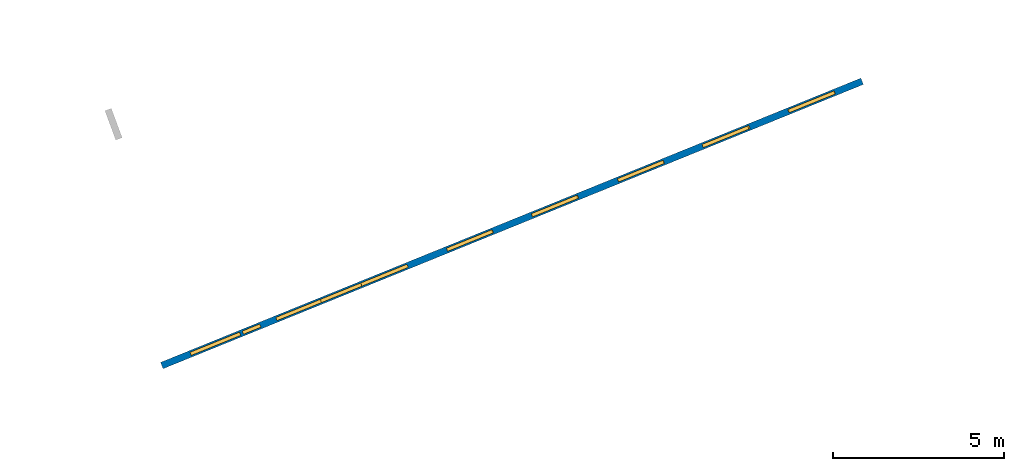
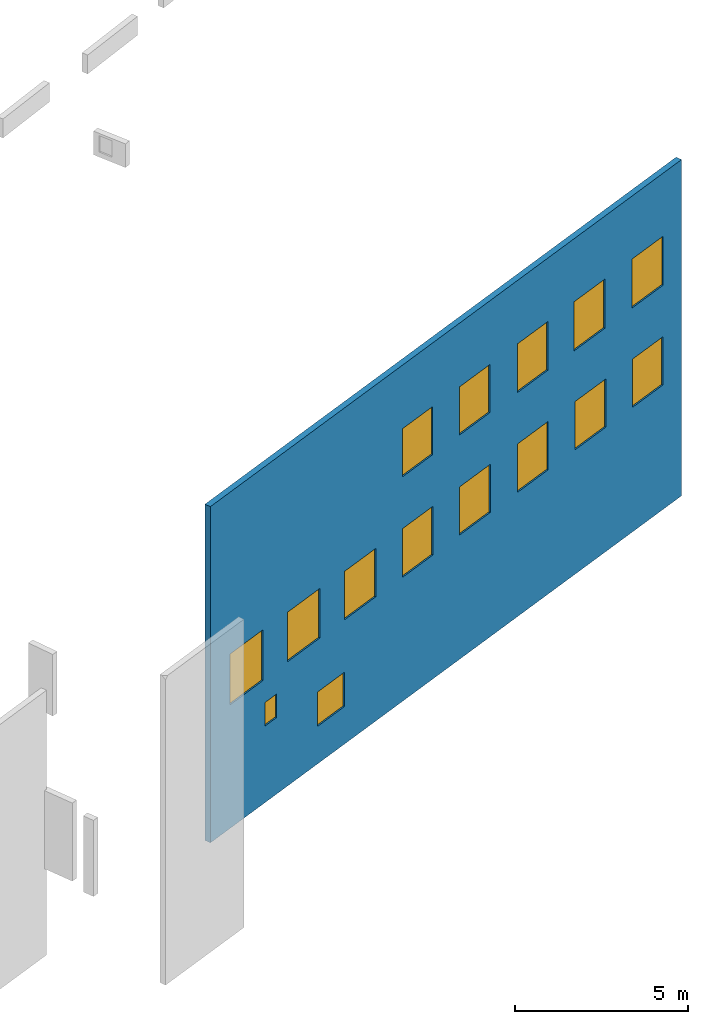
# One storey, part 4 of 27: 15 windows, 1 wall, 15 openings.
"""IFC2X3 building model written with IfcOpenShell, lengths in metres."""

from ifc_helpers import new_model, entity, si_unit, converted_unit, derived_unit, direction, frame, frame_2d, origin, origin_2d_with_axis, place, context, subcontext, project, spatial, polyline, rectangle, outline, extrude, source, transform, mapped, material, layer, layer_set, layer_usage, type_object, type_shapes, element, fill, save


model = new_model("IFC2X3")

# Units and contexts
model_context = context("Model", 3, precision=1e-05, world=origin(), true_north=direction((0.0, 1.0)))
body_context = subcontext(model_context, "Body", "Model", "MODEL_VIEW")
ifc_project = project(units=[si_unit("LENGTHUNIT", "METRE"), si_unit("AREAUNIT", "SQUARE_METRE"), si_unit("VOLUMEUNIT", "CUBIC_METRE"), converted_unit("PLANEANGLEUNIT", "DEGREE", entity("IfcRatioMeasure", 0.0174532925199433), si_unit("PLANEANGLEUNIT", "RADIAN"), dimensions=[0, 0, 0, 0, 0, 0, 0]), si_unit("MASSUNIT", "GRAM", prefix="KILO"), derived_unit("MASSDENSITYUNIT", [(si_unit("MASSUNIT", "GRAM", prefix="KILO"), 1), (si_unit("LENGTHUNIT", "METRE"), -3)]), derived_unit("MOMENTOFINERTIAUNIT", [(si_unit("LENGTHUNIT", "METRE"), 4)]), si_unit("TIMEUNIT", "SECOND"), si_unit("FREQUENCYUNIT", "HERTZ"), si_unit("THERMODYNAMICTEMPERATUREUNIT", "DEGREE_CELSIUS"), derived_unit("THERMALTRANSMITTANCEUNIT", [(si_unit("MASSUNIT", "GRAM", prefix="KILO"), 1), (si_unit("THERMODYNAMICTEMPERATUREUNIT", "KELVIN"), -1), (si_unit("TIMEUNIT", "SECOND"), -3)]), derived_unit("VOLUMETRICFLOWRATEUNIT", [(si_unit("LENGTHUNIT", "METRE"), 3), (si_unit("TIMEUNIT", "SECOND"), -1)]), si_unit("ELECTRICCURRENTUNIT", "AMPERE"), si_unit("ELECTRICVOLTAGEUNIT", "VOLT"), si_unit("POWERUNIT", "WATT"), si_unit("FORCEUNIT", "NEWTON", prefix="KILO"), si_unit("ILLUMINANCEUNIT", "LUX"), si_unit("LUMINOUSFLUXUNIT", "LUMEN"), si_unit("LUMINOUSINTENSITYUNIT", "CANDELA"), derived_unit("USERDEFINED", [(si_unit("MASSUNIT", "GRAM", prefix="KILO"), -1), (si_unit("LENGTHUNIT", "METRE"), -2), (si_unit("TIMEUNIT", "SECOND"), 3), (si_unit("LUMINOUSFLUXUNIT", "LUMEN"), 1)]), derived_unit("LINEARVELOCITYUNIT", [(si_unit("LENGTHUNIT", "METRE"), 1), (si_unit("TIMEUNIT", "SECOND"), -1)]), si_unit("PRESSUREUNIT", "PASCAL"), derived_unit("USERDEFINED", [(si_unit("LENGTHUNIT", "METRE"), -2), (si_unit("MASSUNIT", "GRAM", prefix="KILO"), 1), (si_unit("TIMEUNIT", "SECOND"), -2)]), derived_unit("LINEARFORCEUNIT", [(si_unit("MASSUNIT", "GRAM", prefix="KILO"), 1), (si_unit("LENGTHUNIT", "METRE"), 1), (si_unit("TIMEUNIT", "SECOND"), -2), (si_unit("LENGTHUNIT", "METRE"), -1)]), derived_unit("PLANARFORCEUNIT", [(si_unit("MASSUNIT", "GRAM", prefix="KILO"), 1), (si_unit("LENGTHUNIT", "METRE"), 1), (si_unit("TIMEUNIT", "SECOND"), -2), (si_unit("LENGTHUNIT", "METRE"), -2)])], contexts=[model_context])

# Site, building, storey
placement_1 = place(None, origin())
site = spatial("IfcSite", under=ifc_project, at=placement_1, CompositionType="ELEMENT")
building = spatial("IfcBuilding", under=site, at=placement_1, CompositionType="ELEMENT")
storey_placement = place(placement_1, frame((0.0, 0.0, -61.043098449707)))
storey = spatial("IfcBuildingStorey", under=building, at=storey_placement, Name="level_-61.043098", CompositionType="ELEMENT", Elevation=-61.043098449707)

# Wall, openings, windows
ifc_material_1 = material(Name="Default wall")
ifc_layer = layer(ifc_material_1, 0.2)
ifc_layer_set = layer_set([ifc_layer], Name="wall_thickness_0.2000")
ifc_layer_usage = layer_usage(ifc_layer_set, "AXIS2", "POSITIVE", -0.1)
wall_type = type_object("IfcWallType", Name="wall_thickness_0.2000", PredefinedType="STANDARD", material=ifc_layer_set)
placement_2 = place(placement_1, frame((0.0, 0.0, -60.9578857421875)))
wall_placement = place(placement_2, frame((-3.76886446488196, -59.6963670250745, 0.0), z_axis=(0.0, 0.0, 1.0), x_axis=(0.9265685084533, 0.37612604156403, 0.0)))
wall = element("IfcWallStandardCase", 1, at=wall_placement, inside=storey, type_object=wall_type, material=ifc_layer_usage, Name="Wall:1304", ObjectType="Wall", context=body_context, shape_type="SweptSolid", body=[
    extrude(outline(polyline([(22.1250003143564, -0.1), (22.1250003143564, 0.1), (0.0, 0.1), (0.0, -0.1), (22.1250003143564, -0.1)])), origin(), (0.0, 0.0, 1.0), 11.8396759033203),
])
opening_1_placement = place(wall_placement, frame((5.02385632715691, -0.1, 1.32223892211914)))
opening_1 = element("IfcOpeningElement", 2, at=opening_1_placement, cuts=wall, Name="Opening : 1275 x 1210 : 173", ObjectType="Opening", context=body_context, shape_type="SweptSolid", body=[
    extrude(rectangle(XDim=1.275, YDim=1.21, at=frame_2d((0.605, 0.6375), x_axis=(0.0, 1.0))), frame((0.0, 0.0, 0.0), z_axis=(0.0, 1.0, 0.0), x_axis=(0.0, 0.0, 1.0)), (0.0, 0.0, 1.0), 0.2),
])
opening_2_placement = place(wall_placement, frame((17.0849989237, -0.1, 7.89074325561523)))
opening_2 = element("IfcOpeningElement", 3, at=opening_2_placement, cuts=wall, Name="Opening : 1440 x 1730 : 174", ObjectType="Opening", context=body_context, shape_type="SweptSolid", body=[
    extrude(rectangle(XDim=1.44, YDim=1.73, at=frame_2d((0.865, 0.72), x_axis=(0.0, 1.0))), frame((0.0, 0.0, 0.0), z_axis=(0.0, 1.0, 0.0), x_axis=(0.0, 0.0, 1.0)), (0.0, 0.0, 1.0), 0.2),
])
opening_3_placement = place(wall_placement, frame((19.7949986488983, -0.1, 7.89574432373047)))
opening_3 = element("IfcOpeningElement", 4, at=opening_3_placement, cuts=wall, Name="Opening : 1465 x 1725 : 175", ObjectType="Opening", context=body_context, shape_type="SweptSolid", body=[
    extrude(rectangle(XDim=1.465, YDim=1.725, at=frame_2d((0.8625, 0.7325), x_axis=(0.0, 1.0))), frame((0.0, 0.0, 0.0), z_axis=(0.0, 1.0, 0.0), x_axis=(0.0, 0.0, 1.0)), (0.0, 0.0, 1.0), 0.2),
])
opening_4_placement = place(wall_placement, frame((9.00999836878025, -0.1, 7.90574264526367)))
opening_4 = element("IfcOpeningElement", 5, at=opening_4_placement, cuts=wall, Name="Opening : 1430 x 1695 : 176", ObjectType="Opening", context=body_context, shape_type="SweptSolid", body=[
    extrude(rectangle(XDim=1.43, YDim=1.695, at=frame_2d((0.8475, 0.715), x_axis=(0.0, 1.0))), frame((0.0, 0.0, 0.0), z_axis=(0.0, 1.0, 0.0), x_axis=(0.0, 0.0, 1.0)), (0.0, 0.0, 1.0), 0.2),
])
opening_5_placement = place(wall_placement, frame((14.414998605736, -0.1, 7.89074325561523)))
opening_5 = element("IfcOpeningElement", 6, at=opening_5_placement, cuts=wall, Name="Opening : 1430 x 1715 : 177", ObjectType="Opening", context=body_context, shape_type="SweptSolid", body=[
    extrude(rectangle(XDim=1.43, YDim=1.715, at=frame_2d((0.8575, 0.715), x_axis=(0.0, 1.0))), frame((0.0, 0.0, 0.0), z_axis=(0.0, 1.0, 0.0), x_axis=(0.0, 0.0, 1.0)), (0.0, 0.0, 1.0), 0.2),
])
opening_6_placement = place(wall_placement, frame((11.6899988972545, -0.1, 7.90074157714844)))
opening_6 = element("IfcOpeningElement", 7, at=opening_6_placement, cuts=wall, Name="Opening : 1430 x 1695 : 178", ObjectType="Opening", context=body_context, shape_type="SweptSolid", body=[
    extrude(rectangle(XDim=1.43, YDim=1.695, at=frame_2d((0.8475, 0.715), x_axis=(0.0, 1.0))), frame((0.0, 0.0, 0.0), z_axis=(0.0, 1.0, 0.0), x_axis=(0.0, 0.0, 1.0)), (0.0, 0.0, 1.0), 0.2),
])
opening_7_placement = place(wall_placement, frame((0.909998722391672, -0.1, 4.35074234008789)))
opening_7 = element("IfcOpeningElement", 8, at=opening_7_placement, cuts=wall, Name="Opening : 1565 x 1790 : 179", ObjectType="Opening", context=body_context, shape_type="SweptSolid", body=[
    extrude(rectangle(XDim=1.565, YDim=1.79, at=frame_2d((0.895, 0.7825), x_axis=(0.0, 1.0))), frame((0.0, 0.0, 0.0), z_axis=(0.0, 1.0, 0.0), x_axis=(0.0, 0.0, 1.0)), (0.0, 0.0, 1.0), 0.2),
])
opening_8_placement = place(wall_placement, frame((3.62000032421919, -0.1, 4.3757438659668)))
opening_8 = element("IfcOpeningElement", 9, at=opening_8_placement, cuts=wall, Name="Opening : 1525 x 1745 : 180", ObjectType="Opening", context=body_context, shape_type="SweptSolid", body=[
    extrude(rectangle(XDim=1.525, YDim=1.745, at=frame_2d((0.8725, 0.7625), x_axis=(0.0, 1.0))), frame((0.0, 0.0, 0.0), z_axis=(0.0, 1.0, 0.0), x_axis=(0.0, 0.0, 1.0)), (0.0, 0.0, 1.0), 0.2),
])
opening_9_placement = place(wall_placement, frame((6.30499908131936, -0.1, 4.3757438659668)))
opening_9 = element("IfcOpeningElement", 10, at=opening_9_placement, cuts=wall, Name="Opening : 1460 x 1705 : 181", ObjectType="Opening", context=body_context, shape_type="SweptSolid", body=[
    extrude(rectangle(XDim=1.46, YDim=1.705, at=frame_2d((0.8525, 0.73), x_axis=(0.0, 1.0))), frame((0.0, 0.0, 0.0), z_axis=(0.0, 1.0, 0.0), x_axis=(0.0, 0.0, 1.0)), (0.0, 0.0, 1.0), 0.2),
])
opening_10_placement = place(wall_placement, frame((9.00999836878025, -0.1, 4.36574172973633)))
opening_10 = element("IfcOpeningElement", 11, at=opening_10_placement, cuts=wall, Name="Opening : 1445 x 1715 : 182", ObjectType="Opening", context=body_context, shape_type="SweptSolid", body=[
    extrude(rectangle(XDim=1.445, YDim=1.715, at=frame_2d((0.8575, 0.7225), x_axis=(0.0, 1.0))), frame((0.0, 0.0, 0.0), z_axis=(0.0, 1.0, 0.0), x_axis=(0.0, 0.0, 1.0)), (0.0, 0.0, 1.0), 0.2),
])
opening_11_placement = place(wall_placement, frame((14.4099985004809, -0.1, 4.3757438659668)))
opening_11 = element("IfcOpeningElement", 12, at=opening_11_placement, cuts=wall, Name="Opening : 1450 x 1705 : 183", ObjectType="Opening", context=body_context, shape_type="SweptSolid", body=[
    extrude(rectangle(XDim=1.45, YDim=1.705, at=frame_2d((0.8525, 0.725), x_axis=(0.0, 1.0))), frame((0.0, 0.0, 0.0), z_axis=(0.0, 1.0, 0.0), x_axis=(0.0, 0.0, 1.0)), (0.0, 0.0, 1.0), 0.2),
])
opening_12_placement = place(wall_placement, frame((17.114999555231, -0.1, 4.38074493408203)))
opening_12 = element("IfcOpeningElement", 13, at=opening_12_placement, cuts=wall, Name="Opening : 1450 x 1700 : 184", ObjectType="Opening", context=body_context, shape_type="SweptSolid", body=[
    extrude(rectangle(XDim=1.45, YDim=1.7, at=frame_2d((0.85, 0.725), x_axis=(0.0, 1.0))), frame((0.0, 0.0, 0.0), z_axis=(0.0, 1.0, 0.0), x_axis=(0.0, 0.0, 1.0)), (0.0, 0.0, 1.0), 0.2),
])
opening_13_placement = place(wall_placement, frame((19.8099989646637, -0.1, 4.3857421875)))
opening_13 = element("IfcOpeningElement", 14, at=opening_13_placement, cuts=wall, Name="Opening : 1435 x 1700 : 185", ObjectType="Opening", context=body_context, shape_type="SweptSolid", body=[
    extrude(rectangle(XDim=1.435, YDim=1.7, at=frame_2d((0.85, 0.7175), x_axis=(0.0, 1.0))), frame((0.0, 0.0, 0.0), z_axis=(0.0, 1.0, 0.0), x_axis=(0.0, 0.0, 1.0)), (0.0, 0.0, 1.0), 0.2),
])
opening_14_placement = place(wall_placement, frame((11.6999982241203, -0.1, 4.3757438659668)))
opening_14 = element("IfcOpeningElement", 15, at=opening_14_placement, cuts=wall, Name="Opening : 1450 x 1695 : 186", ObjectType="Opening", context=body_context, shape_type="SweptSolid", body=[
    extrude(rectangle(XDim=1.45, YDim=1.695, at=frame_2d((0.8475, 0.725), x_axis=(0.0, 1.0))), frame((0.0, 0.0, 0.0), z_axis=(0.0, 1.0, 0.0), x_axis=(0.0, 0.0, 1.0)), (0.0, 0.0, 1.0), 0.2),
])
opening_15_placement = place(wall_placement, frame((2.55999877577397, -0.1, 2.69574356079102)))
opening_15 = element("IfcOpeningElement", 16, at=opening_15_placement, cuts=wall, Name="Opening : 550 x 830 : 187", ObjectType="Opening", context=body_context, shape_type="SweptSolid", body=[
    extrude(rectangle(XDim=0.55, YDim=0.83, at=frame_2d((0.415, 0.275), x_axis=(0.0, 1.0))), frame((0.0, 0.0, 0.0), z_axis=(0.0, 1.0, 0.0), x_axis=(0.0, 0.0, 1.0)), (0.0, 0.0, 1.0), 0.2),
])
ifc_material_2 = material(Name="Window Default")
window_style_1 = type_object("IfcWindowStyle", Name="Window : 1275 x 1210mm", ConstructionType="NOTDEFINED", OperationType="NOTDEFINED", ParameterTakesPrecedence=False, Sizeable=False, material=ifc_material_2)
shared_shape_1 = source(origin(), body_context, "Body", "SweptSolid", [
    extrude(rectangle(XDim=0.1, YDim=1.275, at=origin_2d_with_axis()), frame((0.6375, 0.1, 0.0), z_axis=(0.0, 0.0, 1.0), x_axis=(0.0, 1.0, 0.0)), (0.0, 0.0, 1.0), 1.21),
])
type_shapes(window_style_1, [shared_shape_1])
window_1_placement = place(opening_1_placement, origin())
window_1 = element("IfcWindow", 17, at=window_1_placement, inside=storey, type_object=window_style_1, Name="Window : 1275 x 1210mm : 157", ObjectType="Window : 1275 x 1210mm", OverallHeight=1.21, OverallWidth=1.275, context=body_context, shape_type="MappedRepresentation", body=[
    mapped(shared_shape_1, transform((0.0, 0.0, 0.0), scale=1.0)),
])
fill(opening_1, window_1)
window_style_2 = type_object("IfcWindowStyle", Name="Window : 1440 x 1730mm", ConstructionType="NOTDEFINED", OperationType="NOTDEFINED", ParameterTakesPrecedence=False, Sizeable=False, material=ifc_material_2)
shared_shape_2 = source(origin(), body_context, "Body", "SweptSolid", [
    extrude(rectangle(XDim=0.1, YDim=1.44, at=origin_2d_with_axis()), frame((0.72, 0.1, 0.0), z_axis=(0.0, 0.0, 1.0), x_axis=(0.0, 1.0, 0.0)), (0.0, 0.0, 1.0), 1.73),
])
type_shapes(window_style_2, [shared_shape_2])
window_2_placement = place(opening_2_placement, origin())
window_2 = element("IfcWindow", 18, at=window_2_placement, inside=storey, type_object=window_style_2, Name="Window : 1440 x 1730mm : 158", ObjectType="Window : 1440 x 1730mm", OverallHeight=1.73, OverallWidth=1.44, context=body_context, shape_type="MappedRepresentation", body=[
    mapped(shared_shape_2, transform((0.0, 0.0, 0.0), scale=1.0)),
])
fill(opening_2, window_2)
window_style_3 = type_object("IfcWindowStyle", Name="Window : 1465 x 1725mm", ConstructionType="NOTDEFINED", OperationType="NOTDEFINED", ParameterTakesPrecedence=False, Sizeable=False, material=ifc_material_2)
shared_shape_3 = source(origin(), body_context, "Body", "SweptSolid", [
    extrude(rectangle(XDim=0.1, YDim=1.465, at=origin_2d_with_axis()), frame((0.7325, 0.1, 0.0), z_axis=(0.0, 0.0, 1.0), x_axis=(0.0, 1.0, 0.0)), (0.0, 0.0, 1.0), 1.725),
])
type_shapes(window_style_3, [shared_shape_3])
window_3_placement = place(opening_3_placement, origin())
window_3 = element("IfcWindow", 19, at=window_3_placement, inside=storey, type_object=window_style_3, Name="Window : 1465 x 1725mm : 159", ObjectType="Window : 1465 x 1725mm", OverallHeight=1.725, OverallWidth=1.465, context=body_context, shape_type="MappedRepresentation", body=[
    mapped(shared_shape_3, transform((0.0, 0.0, 0.0), scale=1.0)),
])
fill(opening_3, window_3)
window_style_4 = type_object("IfcWindowStyle", Name="Window : 1430 x 1695mm", ConstructionType="NOTDEFINED", OperationType="NOTDEFINED", ParameterTakesPrecedence=False, Sizeable=False, material=ifc_material_2)
shared_shape_4 = source(origin(), body_context, "Body", "SweptSolid", [
    extrude(rectangle(XDim=0.1, YDim=1.43, at=origin_2d_with_axis()), frame((0.715, 0.1, 0.0), z_axis=(0.0, 0.0, 1.0), x_axis=(0.0, 1.0, 0.0)), (0.0, 0.0, 1.0), 1.695),
])
type_shapes(window_style_4, [shared_shape_4])
window_4_placement = place(opening_4_placement, origin())
window_4 = element("IfcWindow", 20, at=window_4_placement, inside=storey, type_object=window_style_4, Name="Window : 1430 x 1695mm : 160", ObjectType="Window : 1430 x 1695mm", OverallHeight=1.695, OverallWidth=1.43, context=body_context, shape_type="MappedRepresentation", body=[
    mapped(shared_shape_4, transform((0.0, 0.0, 0.0), scale=1.0)),
])
fill(opening_4, window_4)
window_5_placement = place(opening_6_placement, origin())
window_5 = element("IfcWindow", 21, at=window_5_placement, inside=storey, type_object=window_style_4, Name="Window : 1430 x 1695mm : 162", ObjectType="Window : 1430 x 1695mm", OverallHeight=1.695, OverallWidth=1.43, context=body_context, shape_type="MappedRepresentation", body=[
    mapped(shared_shape_4, transform((0.0, 0.0, 0.0), scale=1.0)),
])
fill(opening_6, window_5)
window_style_5 = type_object("IfcWindowStyle", Name="Window : 1430 x 1715mm", ConstructionType="NOTDEFINED", OperationType="NOTDEFINED", ParameterTakesPrecedence=False, Sizeable=False, material=ifc_material_2)
shared_shape_5 = source(origin(), body_context, "Body", "SweptSolid", [
    extrude(rectangle(XDim=0.1, YDim=1.43, at=origin_2d_with_axis()), frame((0.715, 0.1, 0.0), z_axis=(0.0, 0.0, 1.0), x_axis=(0.0, 1.0, 0.0)), (0.0, 0.0, 1.0), 1.715),
])
type_shapes(window_style_5, [shared_shape_5])
window_6_placement = place(opening_5_placement, origin())
window_6 = element("IfcWindow", 22, at=window_6_placement, inside=storey, type_object=window_style_5, Name="Window : 1430 x 1715mm : 161", ObjectType="Window : 1430 x 1715mm", OverallHeight=1.715, OverallWidth=1.43, context=body_context, shape_type="MappedRepresentation", body=[
    mapped(shared_shape_5, transform((0.0, 0.0, 0.0), scale=1.0)),
])
fill(opening_5, window_6)
window_style_6 = type_object("IfcWindowStyle", Name="Window : 1565 x 1790mm", ConstructionType="NOTDEFINED", OperationType="NOTDEFINED", ParameterTakesPrecedence=False, Sizeable=False, material=ifc_material_2)
shared_shape_6 = source(origin(), body_context, "Body", "SweptSolid", [
    extrude(rectangle(XDim=0.1, YDim=1.565, at=origin_2d_with_axis()), frame((0.7825, 0.1, 0.0), z_axis=(0.0, 0.0, 1.0), x_axis=(0.0, 1.0, 0.0)), (0.0, 0.0, 1.0), 1.79),
])
type_shapes(window_style_6, [shared_shape_6])
window_7_placement = place(opening_7_placement, origin())
window_7 = element("IfcWindow", 23, at=window_7_placement, inside=storey, type_object=window_style_6, Name="Window : 1565 x 1790mm : 163", ObjectType="Window : 1565 x 1790mm", OverallHeight=1.79, OverallWidth=1.565, context=body_context, shape_type="MappedRepresentation", body=[
    mapped(shared_shape_6, transform((0.0, 0.0, 0.0), scale=1.0)),
])
fill(opening_7, window_7)
window_style_7 = type_object("IfcWindowStyle", Name="Window : 1525 x 1745mm", ConstructionType="NOTDEFINED", OperationType="NOTDEFINED", ParameterTakesPrecedence=False, Sizeable=False, material=ifc_material_2)
shared_shape_7 = source(origin(), body_context, "Body", "SweptSolid", [
    extrude(rectangle(XDim=0.1, YDim=1.525, at=origin_2d_with_axis()), frame((0.7625, 0.1, 0.0), z_axis=(0.0, 0.0, 1.0), x_axis=(0.0, 1.0, 0.0)), (0.0, 0.0, 1.0), 1.745),
])
type_shapes(window_style_7, [shared_shape_7])
window_8_placement = place(opening_8_placement, origin())
window_8 = element("IfcWindow", 24, at=window_8_placement, inside=storey, type_object=window_style_7, Name="Window : 1525 x 1745mm : 164", ObjectType="Window : 1525 x 1745mm", OverallHeight=1.745, OverallWidth=1.525, context=body_context, shape_type="MappedRepresentation", body=[
    mapped(shared_shape_7, transform((0.0, 0.0, 0.0), scale=1.0)),
])
fill(opening_8, window_8)
window_style_8 = type_object("IfcWindowStyle", Name="Window : 1460 x 1705mm", ConstructionType="NOTDEFINED", OperationType="NOTDEFINED", ParameterTakesPrecedence=False, Sizeable=False, material=ifc_material_2)
shared_shape_8 = source(origin(), body_context, "Body", "SweptSolid", [
    extrude(rectangle(XDim=0.1, YDim=1.46, at=origin_2d_with_axis()), frame((0.73, 0.1, 0.0), z_axis=(0.0, 0.0, 1.0), x_axis=(0.0, 1.0, 0.0)), (0.0, 0.0, 1.0), 1.705),
])
type_shapes(window_style_8, [shared_shape_8])
window_9_placement = place(opening_9_placement, origin())
window_9 = element("IfcWindow", 25, at=window_9_placement, inside=storey, type_object=window_style_8, Name="Window : 1460 x 1705mm : 165", ObjectType="Window : 1460 x 1705mm", OverallHeight=1.705, OverallWidth=1.46, context=body_context, shape_type="MappedRepresentation", body=[
    mapped(shared_shape_8, transform((0.0, 0.0, 0.0), scale=1.0)),
])
fill(opening_9, window_9)
window_style_9 = type_object("IfcWindowStyle", Name="Window : 1445 x 1715mm", ConstructionType="NOTDEFINED", OperationType="NOTDEFINED", ParameterTakesPrecedence=False, Sizeable=False, material=ifc_material_2)
shared_shape_9 = source(origin(), body_context, "Body", "SweptSolid", [
    extrude(rectangle(XDim=0.1, YDim=1.445, at=origin_2d_with_axis()), frame((0.7225, 0.1, 0.0), z_axis=(0.0, 0.0, 1.0), x_axis=(0.0, 1.0, 0.0)), (0.0, 0.0, 1.0), 1.715),
])
type_shapes(window_style_9, [shared_shape_9])
window_10_placement = place(opening_10_placement, origin())
window_10 = element("IfcWindow", 26, at=window_10_placement, inside=storey, type_object=window_style_9, Name="Window : 1445 x 1715mm : 166", ObjectType="Window : 1445 x 1715mm", OverallHeight=1.715, OverallWidth=1.445, context=body_context, shape_type="MappedRepresentation", body=[
    mapped(shared_shape_9, transform((0.0, 0.0, 0.0), scale=1.0)),
])
fill(opening_10, window_10)
window_style_10 = type_object("IfcWindowStyle", Name="Window : 1450 x 1705mm", ConstructionType="NOTDEFINED", OperationType="NOTDEFINED", ParameterTakesPrecedence=False, Sizeable=False, material=ifc_material_2)
shared_shape_10 = source(origin(), body_context, "Body", "SweptSolid", [
    extrude(rectangle(XDim=0.1, YDim=1.45, at=origin_2d_with_axis()), frame((0.725, 0.1, 0.0), z_axis=(0.0, 0.0, 1.0), x_axis=(0.0, 1.0, 0.0)), (0.0, 0.0, 1.0), 1.705),
])
type_shapes(window_style_10, [shared_shape_10])
window_11_placement = place(opening_11_placement, origin())
window_11 = element("IfcWindow", 27, at=window_11_placement, inside=storey, type_object=window_style_10, Name="Window : 1450 x 1705mm : 167", ObjectType="Window : 1450 x 1705mm", OverallHeight=1.705, OverallWidth=1.45, context=body_context, shape_type="MappedRepresentation", body=[
    mapped(shared_shape_10, transform((0.0, 0.0, 0.0), scale=1.0)),
])
fill(opening_11, window_11)
window_style_11 = type_object("IfcWindowStyle", Name="Window : 1450 x 1700mm", ConstructionType="NOTDEFINED", OperationType="NOTDEFINED", ParameterTakesPrecedence=False, Sizeable=False, material=ifc_material_2)
shared_shape_11 = source(origin(), body_context, "Body", "SweptSolid", [
    extrude(rectangle(XDim=0.1, YDim=1.45, at=origin_2d_with_axis()), frame((0.725, 0.1, 0.0), z_axis=(0.0, 0.0, 1.0), x_axis=(0.0, 1.0, 0.0)), (0.0, 0.0, 1.0), 1.7),
])
type_shapes(window_style_11, [shared_shape_11])
window_12_placement = place(opening_12_placement, origin())
window_12 = element("IfcWindow", 28, at=window_12_placement, inside=storey, type_object=window_style_11, Name="Window : 1450 x 1700mm : 168", ObjectType="Window : 1450 x 1700mm", OverallHeight=1.7, OverallWidth=1.45, context=body_context, shape_type="MappedRepresentation", body=[
    mapped(shared_shape_11, transform((0.0, 0.0, 0.0), scale=1.0)),
])
fill(opening_12, window_12)
window_style_12 = type_object("IfcWindowStyle", Name="Window : 1435 x 1700mm", ConstructionType="NOTDEFINED", OperationType="NOTDEFINED", ParameterTakesPrecedence=False, Sizeable=False, material=ifc_material_2)
shared_shape_12 = source(origin(), body_context, "Body", "SweptSolid", [
    extrude(rectangle(XDim=0.1, YDim=1.435, at=origin_2d_with_axis()), frame((0.7175, 0.1, 0.0), z_axis=(0.0, 0.0, 1.0), x_axis=(0.0, 1.0, 0.0)), (0.0, 0.0, 1.0), 1.7),
])
type_shapes(window_style_12, [shared_shape_12])
window_13_placement = place(opening_13_placement, origin())
window_13 = element("IfcWindow", 29, at=window_13_placement, inside=storey, type_object=window_style_12, Name="Window : 1435 x 1700mm : 169", ObjectType="Window : 1435 x 1700mm", OverallHeight=1.7, OverallWidth=1.435, context=body_context, shape_type="MappedRepresentation", body=[
    mapped(shared_shape_12, transform((0.0, 0.0, 0.0), scale=1.0)),
])
fill(opening_13, window_13)
window_style_13 = type_object("IfcWindowStyle", Name="Window : 1450 x 1695mm", ConstructionType="NOTDEFINED", OperationType="NOTDEFINED", ParameterTakesPrecedence=False, Sizeable=False, material=ifc_material_2)
shared_shape_13 = source(origin(), body_context, "Body", "SweptSolid", [
    extrude(rectangle(XDim=0.1, YDim=1.45, at=origin_2d_with_axis()), frame((0.725, 0.1, 0.0), z_axis=(0.0, 0.0, 1.0), x_axis=(0.0, 1.0, 0.0)), (0.0, 0.0, 1.0), 1.695),
])
type_shapes(window_style_13, [shared_shape_13])
window_14_placement = place(opening_14_placement, origin())
window_14 = element("IfcWindow", 30, at=window_14_placement, inside=storey, type_object=window_style_13, Name="Window : 1450 x 1695mm : 170", ObjectType="Window : 1450 x 1695mm", OverallHeight=1.695, OverallWidth=1.45, context=body_context, shape_type="MappedRepresentation", body=[
    mapped(shared_shape_13, transform((0.0, 0.0, 0.0), scale=1.0)),
])
fill(opening_14, window_14)
window_style_14 = type_object("IfcWindowStyle", Name="Window : 550 x 830mm", ConstructionType="NOTDEFINED", OperationType="NOTDEFINED", ParameterTakesPrecedence=False, Sizeable=False, material=ifc_material_2)
shared_shape_14 = source(origin(), body_context, "Body", "SweptSolid", [
    extrude(rectangle(XDim=0.1, YDim=0.55, at=origin_2d_with_axis()), frame((0.275, 0.1, 0.0), z_axis=(0.0, 0.0, 1.0), x_axis=(0.0, 1.0, 0.0)), (0.0, 0.0, 1.0), 0.83),
])
type_shapes(window_style_14, [shared_shape_14])
window_15_placement = place(opening_15_placement, origin())
window_15 = element("IfcWindow", 31, at=window_15_placement, inside=storey, type_object=window_style_14, Name="Window : 550 x 830mm : 171", ObjectType="Window : 550 x 830mm", OverallHeight=0.83, OverallWidth=0.55, context=body_context, shape_type="MappedRepresentation", body=[
    mapped(shared_shape_14, transform((0.0, 0.0, 0.0), scale=1.0)),
])
fill(opening_15, window_15)

save(model, "model.ifc")
